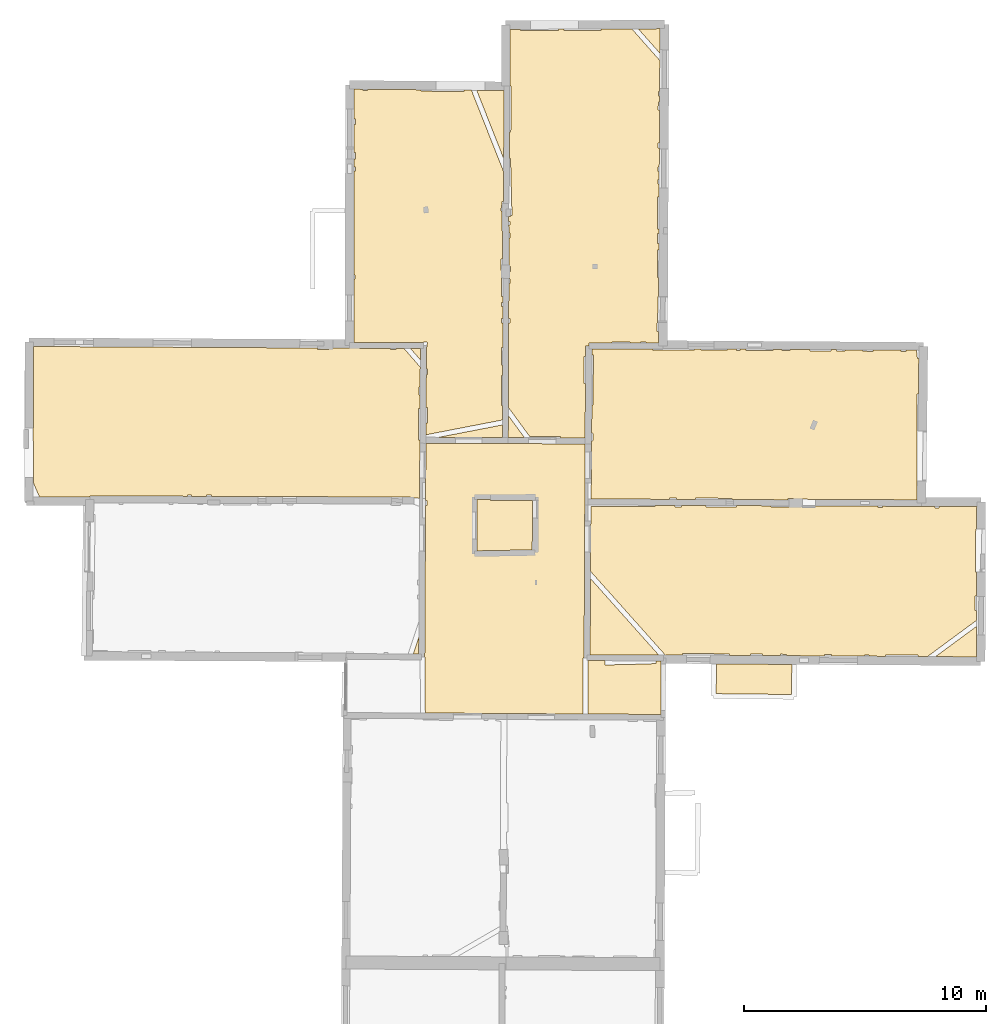
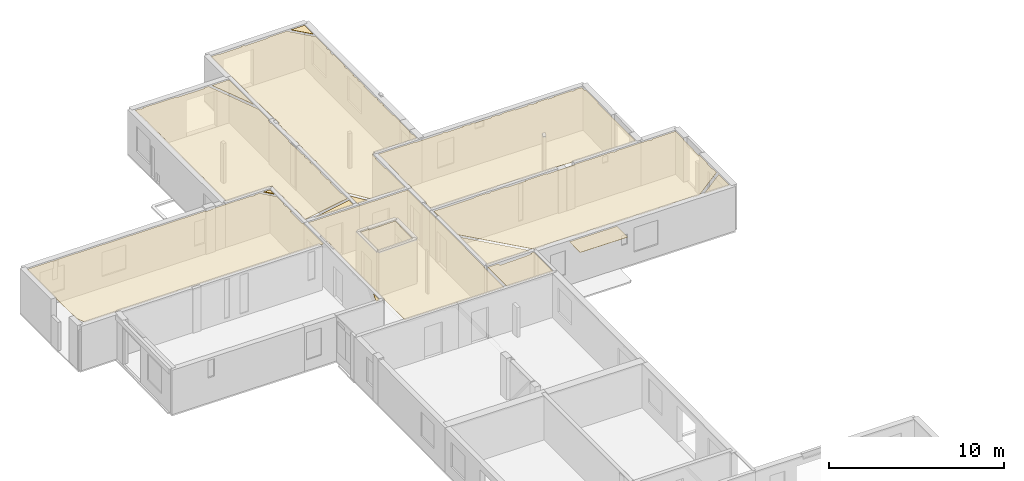
# One storey, part 15 of 17: 17 coverings.
"""IFC2X3 building model written with IfcOpenShell, lengths in metres."""

from ifc_helpers import new_model, entity, si_unit, converted_unit, derived_unit, direction, frame, origin, origin_with_axes, place, context, subcontext, project, spatial, polyline, outline, extrude, material, layer, layer_set, layer_usage, type_object, element, save


model = new_model("IFC2X3")

# Units and contexts
model_context = context("Model", 3, precision=1e-05, world=origin(), true_north=direction((0.0, 1.0)))
body_context = subcontext(model_context, "Body", "Model", "MODEL_VIEW")
ifc_project = project(units=[si_unit("LENGTHUNIT", "METRE"), si_unit("AREAUNIT", "SQUARE_METRE"), si_unit("VOLUMEUNIT", "CUBIC_METRE"), converted_unit("PLANEANGLEUNIT", "DEGREE", entity("IfcRatioMeasure", 0.0174532925199433), si_unit("PLANEANGLEUNIT", "RADIAN"), dimensions=[0, 0, 0, 0, 0, 0, 0]), si_unit("MASSUNIT", "GRAM", prefix="KILO"), derived_unit("MASSDENSITYUNIT", [(si_unit("MASSUNIT", "GRAM", prefix="KILO"), 1), (si_unit("LENGTHUNIT", "METRE"), -3)]), derived_unit("MOMENTOFINERTIAUNIT", [(si_unit("LENGTHUNIT", "METRE"), 4)]), si_unit("TIMEUNIT", "SECOND"), si_unit("FREQUENCYUNIT", "HERTZ"), si_unit("THERMODYNAMICTEMPERATUREUNIT", "DEGREE_CELSIUS"), derived_unit("THERMALTRANSMITTANCEUNIT", [(si_unit("MASSUNIT", "GRAM", prefix="KILO"), 1), (si_unit("THERMODYNAMICTEMPERATUREUNIT", "KELVIN"), -1), (si_unit("TIMEUNIT", "SECOND"), -3)]), derived_unit("VOLUMETRICFLOWRATEUNIT", [(si_unit("LENGTHUNIT", "METRE"), 3), (si_unit("TIMEUNIT", "SECOND"), -1)]), si_unit("ELECTRICCURRENTUNIT", "AMPERE"), si_unit("ELECTRICVOLTAGEUNIT", "VOLT"), si_unit("POWERUNIT", "WATT"), si_unit("FORCEUNIT", "NEWTON", prefix="KILO"), si_unit("ILLUMINANCEUNIT", "LUX"), si_unit("LUMINOUSFLUXUNIT", "LUMEN"), si_unit("LUMINOUSINTENSITYUNIT", "CANDELA"), derived_unit("USERDEFINED", [(si_unit("MASSUNIT", "GRAM", prefix="KILO"), -1), (si_unit("LENGTHUNIT", "METRE"), -2), (si_unit("TIMEUNIT", "SECOND"), 3), (si_unit("LUMINOUSFLUXUNIT", "LUMEN"), 1)]), derived_unit("LINEARVELOCITYUNIT", [(si_unit("LENGTHUNIT", "METRE"), 1), (si_unit("TIMEUNIT", "SECOND"), -1)]), si_unit("PRESSUREUNIT", "PASCAL"), derived_unit("USERDEFINED", [(si_unit("LENGTHUNIT", "METRE"), -2), (si_unit("MASSUNIT", "GRAM", prefix="KILO"), 1), (si_unit("TIMEUNIT", "SECOND"), -2)]), derived_unit("LINEARFORCEUNIT", [(si_unit("MASSUNIT", "GRAM", prefix="KILO"), 1), (si_unit("LENGTHUNIT", "METRE"), 1), (si_unit("TIMEUNIT", "SECOND"), -2), (si_unit("LENGTHUNIT", "METRE"), -1)]), derived_unit("PLANARFORCEUNIT", [(si_unit("MASSUNIT", "GRAM", prefix="KILO"), 1), (si_unit("LENGTHUNIT", "METRE"), 1), (si_unit("TIMEUNIT", "SECOND"), -2), (si_unit("LENGTHUNIT", "METRE"), -2)])], contexts=[model_context])

# Site, building, storey
placement = place(None, origin())
site = spatial("IfcSite", under=ifc_project, at=placement, CompositionType="ELEMENT")
building = spatial("IfcBuilding", under=site, at=placement, CompositionType="ELEMENT")
storey_placement = place(placement, frame((0.0, 0.0, 12.0782108306885)))
storey = spatial("IfcBuildingStorey", under=building, at=storey_placement, Name="Level 5", CompositionType="ELEMENT", Elevation=12.0782108306885)

# Coverings
ifc_material = material(Name="Covering default")
ifc_layer_1 = layer(ifc_material, 0.02)
ifc_layer_set_1 = layer_set([ifc_layer_1], Name="Covering : 20mm")
ifc_layer_usage_1 = layer_usage(ifc_layer_set_1, "AXIS3", "POSITIVE", 0.0)
covering_type_1 = type_object("IfcCoveringType", Name="Covering : 20mm", PredefinedType="CEILING")
covering_1_placement = place(placement, frame((0.0, 0.0, 15.0685014724731)))
element("IfcCovering", 1, at=covering_1_placement, inside=storey, type_object=covering_type_1, material=ifc_layer_usage_1, Name="Covering : 20mm", ObjectType="Covering : 20mm", PredefinedType="CEILING", context=body_context, shape_type="SweptSolid", body=[
    extrude(outline(polyline([(9.7904806137085, 51.0600814819336), (10.4933347702026, 51.0579490661621), (10.4976015090942, 50.8820762634277), (12.4128408432007, 50.9285469055176), (12.4123678207397, 50.9480133056641), (12.6124906539917, 50.9501876831055), (12.6113901138306, 51.0515213012695), (12.8225831985474, 51.0508804321289), (12.8118028640747, 48.838264465332), (9.79118824005127, 48.856689453125), (9.7904806137085, 51.0600814819336)])), origin_with_axes(), (0.0, 0.0, 1.0), 0.02),
])
ifc_layer_2 = layer(ifc_material, 0.02)
ifc_layer_set_2 = layer_set([ifc_layer_2], Name="Covering : 20mm")
ifc_layer_usage_2 = layer_usage(ifc_layer_set_2, "AXIS3", "POSITIVE", 0.0)
covering_type_2 = type_object("IfcCoveringType", Name="Covering : 20mm", PredefinedType="CEILING")
covering_2_placement = place(placement, frame((0.0, 0.0, 15.0685014724731)))
element("IfcCovering", 2, at=covering_2_placement, inside=storey, type_object=covering_type_2, material=ifc_layer_usage_2, Name="Covering : 20mm", ObjectType="Covering : 20mm", PredefinedType="CEILING", context=body_context, shape_type="SweptSolid", body=[
    extrude(outline(polyline([(3.08351039886475, 57.4632720947266), (3.13843250274658, 57.4632911682129), (3.13836765289307, 57.6694068908691), (3.08463573455811, 57.6693878173828), (3.09758472442627, 60.0438919067383), (9.67573261260986, 60.0161056518555), (9.66755962371826, 58.3527603149414), (9.63231945037842, 51.1803703308105), (9.59044361114502, 51.1803550720215), (9.59118938446045, 48.85791015625), (6.44472026824951, 48.8771018981934), (6.44472026824951, 48.8771018981934), (3.07143878936768, 48.8976783752441), (3.05984020233154, 51.210807800293), (3.04940891265869, 51.2107543945312), (3.08351039886475, 57.4632720947266)])), origin_with_axes(), (0.0, 0.0, 1.0), 0.02),
])
ifc_layer_3 = layer(ifc_material, 0.02)
ifc_layer_set_3 = layer_set([ifc_layer_3], Name="Covering : 20mm")
ifc_layer_usage_3 = layer_usage(ifc_layer_set_3, "AXIS3", "POSITIVE", 0.0)
covering_type_3 = type_object("IfcCoveringType", Name="Covering : 20mm", PredefinedType="CEILING")
covering_3_placement = place(placement, frame((0.0, 0.0, 15.0685014724731)))
element("IfcCovering", 3, at=covering_3_placement, inside=storey, type_object=covering_type_3, material=ifc_layer_usage_3, Name="Covering : 20mm", ObjectType="Covering : 20mm", PredefinedType="CEILING", context=body_context, shape_type="SweptSolid", body=[
    extrude(outline(polyline([(15.1055517196655, 50.9264907836914), (18.2173767089844, 50.906078338623), (18.2084465026855, 49.662410736084), (15.090048789978, 49.6961326599121), (15.1055517196655, 50.9264907836914)])), origin_with_axes(), (0.0, 0.0, 1.0), 0.02),
])
ifc_layer_4 = layer(ifc_material, 0.02)
ifc_layer_set_4 = layer_set([ifc_layer_4], Name="Covering : 20mm")
ifc_layer_usage_4 = layer_usage(ifc_layer_set_4, "AXIS3", "POSITIVE", 0.0)
covering_type_4 = type_object("IfcCoveringType", Name="Covering : 20mm", PredefinedType="CEILING")
covering_4_placement = place(placement, frame((0.0, 0.0, 15.0685014724731)))
element("IfcCovering", 4, at=covering_4_placement, inside=storey, type_object=covering_type_4, material=ifc_layer_usage_4, Name="Covering : 20mm", ObjectType="Covering : 20mm", PredefinedType="CEILING", context=body_context, shape_type="SweptSolid", body=[
    extrude(outline(polyline([(24.1548767089844, 51.2271385192871), (25.8434677124023, 52.4721984863281), (25.8394622802734, 51.2160873413086), (24.1548767089844, 51.2271385192871)])), origin_with_axes(), (0.0, 0.0, 1.0), 0.02),
])
ifc_layer_5 = layer(ifc_material, 0.02)
ifc_layer_set_5 = layer_set([ifc_layer_5], Name="Covering : 20mm")
ifc_layer_usage_5 = layer_usage(ifc_layer_set_5, "AXIS3", "POSITIVE", 0.0)
covering_type_5 = type_object("IfcCoveringType", Name="Covering : 20mm", PredefinedType="CEILING")
covering_5_placement = place(placement, frame((0.0, 0.0, 15.0685014724731)))
element("IfcCovering", 5, at=covering_5_placement, inside=storey, type_object=covering_type_5, material=ifc_layer_usage_5, Name="Covering : 20mm", ObjectType="Covering : 20mm", PredefinedType="CEILING", context=body_context, shape_type="SweptSolid", body=[
    extrude(outline(polyline([(13.0087194442749, 51.2693481445312), (13.00892162323, 51.3002510070801), (13.7004079818726, 51.2957153320312), (13.7003927230835, 51.3473663330078), (15.0095586776733, 51.3477821350098), (15.0095624923706, 51.3377838134766), (15.6403951644897, 51.3379859924316), (15.6404123306274, 51.2829895019531), (16.500415802002, 51.2773475646973), (16.5004005432129, 51.3282623291016), (17.0103988647461, 51.3284225463867), (17.0104141235352, 51.2740020751953), (17.7579345703125, 51.269100189209), (17.7603988647461, 51.3286628723145), (18.0004005432129, 51.3187408447266), (17.9982833862305, 51.2675247192383), (19.5704193115234, 51.257209777832), (19.5704040527344, 51.3092422485352), (19.8504066467285, 51.3093338012695), (19.8504257202148, 51.2553749084473), (21.2304267883301, 51.2463226318359), (21.2304077148438, 51.2997741699219), (21.4104080200195, 51.2998352050781), (21.4104270935059, 51.2451400756836), (22.0899848937988, 51.2406845092773), (22.0904083251953, 51.300048828125), (23.4304122924805, 51.2904815673828), (23.4299926757812, 51.2318916320801), (23.8208427429199, 51.2293281555176), (25.8442649841309, 52.7212715148926), (25.8456039428711, 53.1412544250488), (25.7898216247559, 53.1412353515625), (25.7896270751953, 53.7412338256836), (25.8475151062012, 53.7412528991699), (25.8506393432617, 54.7206802368164), (25.7993125915527, 54.7212371826172), (25.8187408447266, 56.5112457275391), (25.8563461303711, 56.5108375549316), (25.8592872619629, 57.4330902099609), (24.3084487915039, 57.4254455566406), (24.3084678649902, 57.3707618713379), (24.1384658813477, 57.3707046508789), (24.1384468078613, 57.4246063232422), (23.578426361084, 57.4218444824219), (23.5783615112305, 57.4350357055664), (21.9684410095215, 57.4415512084961), (21.9684600830078, 57.3900146484375), (21.7684593200684, 57.3899459838867), (21.768440246582, 57.4423599243164), (19.1881828308105, 57.4528007507324), (19.1884460449219, 57.4291229248047), (17.3484535217285, 57.4085311889648), (17.3478736877441, 57.4602394104004), (15.9288911819458, 57.4659805297852), (15.9284505844116, 57.4080772399902), (14.6684484481812, 57.4176750183105), (14.6688547134399, 57.471076965332), (13.6584310531616, 57.4751663208008), (13.6584501266479, 57.417350769043), (13.3884496688843, 57.4172668457031), (13.3884305953979, 57.4762573242188), (12.5686368942261, 57.4795761108398), (12.5684461593628, 57.427001953125), (9.91423511505127, 57.4366035461426), (9.91261959075928, 57.3470039367676), (9.89987468719482, 54.7527770996094), (13.0087194442749, 51.2693481445312)])), origin_with_axes(), (0.0, 0.0, 1.0), 0.02),
])
ifc_layer_6 = layer(ifc_material, 0.02)
ifc_layer_set_6 = layer_set([ifc_layer_6], Name="Covering : 20mm")
ifc_layer_usage_6 = layer_usage(ifc_layer_set_6, "AXIS3", "POSITIVE", 0.0)
covering_type_6 = type_object("IfcCoveringType", Name="Covering : 20mm", PredefinedType="CEILING")
covering_6_placement = place(placement, frame((0.0, 0.0, 15.0685014724731)))
element("IfcCovering", 6, at=covering_6_placement, inside=storey, type_object=covering_type_6, material=ifc_layer_usage_6, Name="Covering : 20mm", ObjectType="Covering : 20mm", PredefinedType="CEILING", context=body_context, shape_type="SweptSolid", body=[
    extrude(outline(polyline([(9.89840793609619, 54.4540519714355), (12.7201337814331, 51.2923355102539), (9.88291072845459, 51.2998008728027), (9.89840793609619, 54.4540519714355)])), origin_with_axes(), (0.0, 0.0, 1.0), 0.02),
])
ifc_layer_7 = layer(ifc_material, 0.02)
ifc_layer_set_7 = layer_set([ifc_layer_7], Name="Covering : 20mm")
ifc_layer_usage_7 = layer_usage(ifc_layer_set_7, "AXIS3", "POSITIVE", 0.0)
covering_type_7 = type_object("IfcCoveringType", Name="Covering : 20mm", PredefinedType="CEILING")
covering_7_placement = place(placement, frame((0.0, 0.0, 15.0685014724731)))
element("IfcCovering", 7, at=covering_7_placement, inside=storey, type_object=covering_type_7, material=ifc_layer_usage_7, Name="Covering : 20mm", ObjectType="Covering : 20mm", PredefinedType="CEILING", context=body_context, shape_type="SweptSolid", body=[
    extrude(outline(polyline([(2.80388736724854, 52.0325698852539), (2.80006504058838, 51.331672668457), (2.57115459442139, 51.3336219787598), (2.80388736724854, 52.0325698852539)])), origin_with_axes(), (0.0, 0.0, 1.0), 0.02),
])
ifc_layer_8 = layer(ifc_material, 0.02)
ifc_layer_set_8 = layer_set([ifc_layer_8], Name="Covering : 20mm")
ifc_layer_usage_8 = layer_usage(ifc_layer_set_8, "AXIS3", "POSITIVE", 0.0)
covering_type_8 = type_object("IfcCoveringType", Name="Covering : 20mm", PredefinedType="CEILING")
covering_8_placement = place(placement, frame((0.0, 0.0, 15.0685014724731)))
element("IfcCovering", 8, at=covering_8_placement, inside=storey, type_object=covering_type_8, material=ifc_layer_usage_8, Name="Covering : 20mm", ObjectType="Covering : 20mm", PredefinedType="CEILING", context=body_context, shape_type="SweptSolid", body=[
    extrude(outline(polyline([(5.20810413360596, 57.7236480712891), (5.77539920806885, 57.7263565063477), (5.77566814422607, 57.6787643432617), (7.50057125091553, 57.6885032653809), (7.49057674407959, 55.6396179199219), (5.20288181304932, 55.5982627868652), (5.20810413360596, 57.7236480712891)])), origin_with_axes(), (0.0, 0.0, 1.0), 0.02),
])
ifc_layer_9 = layer(ifc_material, 0.02)
ifc_layer_set_9 = layer_set([ifc_layer_9], Name="Covering : 20mm")
ifc_layer_usage_9 = layer_usage(ifc_layer_set_9, "AXIS3", "POSITIVE", 0.0)
covering_type_9 = type_object("IfcCoveringType", Name="Covering : 20mm", PredefinedType="CEILING")
covering_9_placement = place(placement, frame((0.0, 0.0, 15.0685014724731)))
element("IfcCovering", 9, at=covering_9_placement, inside=storey, type_object=covering_type_9, material=ifc_layer_usage_9, Name="Covering : 20mm", ObjectType="Covering : 20mm", PredefinedType="CEILING", context=body_context, shape_type="SweptSolid", body=[
    extrude(outline(polyline([(9.93150424957275, 58.3950958251953), (9.93776988983154, 58.3950653076172), (9.94572925567627, 60.0148696899414), (9.94572925567627, 60.0148696899414), (9.94633007049561, 60.1373023986816), (9.99067211151123, 60.1349830627441), (10.0074758529663, 60.456184387207), (9.94791316986084, 60.459300994873), (9.95364856719971, 61.6264228820801), (10.0071020126343, 61.6261825561523), (10.0164384841919, 63.6961860656738), (9.96381855010986, 63.6964225769043), (9.96505069732666, 63.9469871520996), (12.476056098938, 63.9395027160645), (12.4763765335083, 63.8869743347168), (14.206374168396, 63.897533416748), (14.2060689926147, 63.947566986084), (14.4663572311401, 63.9458656311035), (14.4663763046265, 63.8876152038574), (15.5563764572144, 63.8879661560059), (15.5563592910767, 63.9387245178223), (15.9263601303101, 63.9362983703613), (15.9263792037964, 63.8780784606934), (16.0863800048828, 63.8781318664551), (16.0863609313965, 63.9352531433105), (16.3268623352051, 63.9336738586426), (16.3263816833496, 63.8782081604004), (17.4363822937012, 63.8685646057129), (17.4368858337402, 63.9264030456543), (17.8163642883301, 63.9239158630371), (17.8163833618164, 63.8686866760254), (18.1463851928711, 63.8687934875488), (18.1463661193848, 63.9217567443848), (18.9663696289062, 63.9163856506348), (18.9663887023926, 63.8590507507324), (19.8363876342773, 63.8593330383301), (19.8363723754883, 63.9106864929199), (20.0563735961914, 63.9092445373535), (20.0563926696777, 63.8493995666504), (20.416389465332, 63.8495216369629), (20.4163703918457, 63.9068870544434), (21.147590637207, 63.9020957946777), (21.1463890075684, 63.8497505187988), (21.5763931274414, 63.8398933410645), (21.5777549743652, 63.8992729187012), (22.7363777160645, 63.8916893005371), (22.7363929748535, 63.840259552002), (22.9263954162598, 63.8403205871582), (22.9263801574707, 63.890438079834), (23.3702659606934, 63.8875312805176), (23.4064865112305, 63.550479888916), (23.4652824401855, 63.5567970275879), (23.4472236633301, 62.0803451538086), (23.3969573974609, 62.0804672241211), (23.3937110900879, 57.7057838439941), (19.1945037841797, 57.7227745056152), (19.1944885253906, 57.7189064025879), (18.0683403015137, 57.7587623596191), (18.0665168762207, 57.707332611084), (15.7480154037476, 57.7167129516602), (15.7483358383179, 57.7680206298828), (14.2283315658569, 57.7775344848633), (14.2279901504517, 57.7228622436523), (13.4483480453491, 57.726016998291), (13.4483327865601, 57.7772827148438), (13.1683340072632, 57.7771949768066), (13.1683492660522, 57.7271499633789), (9.91970539093018, 57.740291595459), (9.93150424957275, 58.3950958251953)])), origin_with_axes(), (0.0, 0.0, 1.0), 0.02),
])
ifc_layer_10 = layer(ifc_material, 0.02)
ifc_layer_set_10 = layer_set([ifc_layer_10], Name="Covering : 20mm")
ifc_layer_usage_10 = layer_usage(ifc_layer_set_10, "AXIS3", "POSITIVE", 0.0)
covering_type_10 = type_object("IfcCoveringType", Name="Covering : 20mm", PredefinedType="CEILING")
covering_10_placement = place(placement, frame((0.0, 0.0, 15.0685014724731)))
element("IfcCovering", 10, at=covering_10_placement, inside=storey, type_object=covering_type_10, material=ifc_layer_usage_10, Name="Covering : 20mm", ObjectType="Covering : 20mm", PredefinedType="CEILING", context=body_context, shape_type="SweptSolid", body=[
    extrude(outline(polyline([(-13.1075763702393, 58.3783416748047), (-12.868932723999, 57.826171875), (-10.7861461639404, 57.8319511413574), (-10.7860221862793, 57.8676414489746), (-6.75169277191162, 57.8536834716797), (-6.75171232223511, 57.910816192627), (-6.58171033859253, 57.9108734130859), (-6.58169078826904, 57.8530960083008), (-5.96169281005859, 57.8509483337402), (-5.96170854568481, 57.9010696411133), (-5.76170778274536, 57.9011344909668), (-5.76169109344482, 57.8502578735352), (2.46896457672119, 57.8217811584473), (2.47573947906494, 57.7743721008301), (2.83518695831299, 57.7711868286133), (2.84826755523682, 60.1697235107422), (2.79756641387939, 60.1697082519531), (2.79714488983154, 61.4838714599609), (2.85543537139893, 61.4838905334473), (2.85848903656006, 62.0438919067383), (2.80696582794189, 62.0438766479492), (2.80686092376709, 62.3738784790039), (2.86028957366943, 62.3738975524902), (2.86472225189209, 63.186595916748), (2.19258403778076, 63.9643592834473), (1.85634994506836, 63.9647331237793), (1.85636711120605, 63.9135780334473), (1.62636756896973, 63.913501739502), (1.62635040283203, 63.9649925231934), (1.13216686248779, 63.9655342102051), (-0.913651466369629, 63.9765205383301), (-0.913634300231934, 63.9226875305176), (-1.38363552093506, 63.9225425720215), (-1.38365364074707, 63.9790458679199), (-13.1240291595459, 64.0420837402344), (-13.1264801025391, 60.6716423034668), (-13.1325941085815, 60.6716461181641), (-13.1324920654297, 60.3525085449219), (-13.1289682388306, 60.3525009155273), (-13.1075763702393, 58.3783416748047)])), origin_with_axes(), (0.0, 0.0, 1.0), 0.02),
])
ifc_layer_11 = layer(ifc_material, 0.02)
ifc_layer_set_11 = layer_set([ifc_layer_11], Name="Covering : 20mm")
ifc_layer_usage_11 = layer_usage(ifc_layer_set_11, "AXIS3", "POSITIVE", 0.0)
covering_type_11 = type_object("IfcCoveringType", Name="Covering : 20mm", PredefinedType="CEILING")
covering_11_placement = place(placement, frame((0.0, 0.0, 15.0685014724731)))
element("IfcCovering", 11, at=covering_11_placement, inside=storey, type_object=covering_type_11, material=ifc_layer_usage_11, Name="Covering : 20mm", ObjectType="Covering : 20mm", PredefinedType="CEILING", context=body_context, shape_type="SweptSolid", body=[
    extrude(outline(polyline([(7.38483905792236, 60.3253440856934), (8.6575174331665, 60.3257522583008), (8.6575345993042, 60.2704048156738), (9.67696094512939, 60.2660980224609), (9.68801593780518, 62.5160789489746), (9.63681697845459, 62.5160636901855), (9.63646221160889, 63.6260643005371), (9.69346904754639, 63.6260795593262), (9.69564151763916, 64.0680541992188), (9.830641746521, 64.0673904418945), (9.83100032806396, 64.187385559082), (10.7962808609009, 64.1845092773438), (10.7962636947632, 64.2364349365234), (11.5262632369995, 64.2366714477539), (11.5262804031372, 64.1823272705078), (11.956280708313, 64.1810455322266), (11.9562635421753, 64.2368087768555), (12.1862630844116, 64.2368774414062), (12.1862802505493, 64.1803588867188), (12.7114896774292, 64.1787948608398), (12.7140283584595, 64.6670455932617), (12.6561269760132, 64.6670303344727), (12.6560182571411, 65.0070343017578), (12.6759080886841, 65.0284881591797), (12.6815595626831, 66.1145858764648), (12.71155834198, 66.1144332885742), (12.7156286239624, 66.8970489501953), (12.6654119491577, 66.8970336914062), (12.6650533676147, 68.0270385742188), (12.7215070724487, 68.0270538330078), (12.7229566574097, 68.3056030273438), (12.6649618148804, 68.3070373535156), (12.6748342514038, 68.7070388793945), (12.7250375747681, 68.7058029174805), (12.7260847091675, 68.9070587158203), (12.6747694015503, 68.9070434570312), (12.6743497848511, 70.217041015625), (12.7328977584839, 70.2170562744141), (12.7356557846069, 70.7470550537109), (12.6841802597046, 70.7470397949219), (12.6841154098511, 70.9470367431641), (12.7366952896118, 70.9470520019531), (12.7384119033813, 71.2770538330078), (12.6840124130249, 71.2770385742188), (12.6839513778687, 71.467041015625), (12.7393999099731, 71.4670562744141), (12.743390083313, 72.2342224121094), (12.6837034225464, 72.2370452880859), (12.6936368942261, 72.4470443725586), (12.7444849014282, 72.4446411132812), (12.7515630722046, 73.8052978515625), (12.6932020187378, 73.8070449829102), (12.7030973434448, 74.1370468139648), (12.7532796859741, 74.1355438232422), (12.7546415328979, 74.3970642089844), (12.703013420105, 74.3970489501953), (12.7029523849487, 74.5870513916016), (12.7556295394897, 74.5870666503906), (12.7622537612915, 75.8607940673828), (11.607798576355, 77.166877746582), (10.3417711257935, 77.161003112793), (10.3421468734741, 77.1062927246094), (8.81214809417725, 77.0958023071289), (8.81174945831299, 77.1539077758789), (8.57213115692139, 77.1527938842773), (8.57215023040771, 77.0957260131836), (7.01214694976807, 77.0952301025391), (7.012131690979, 77.1455535888672), (6.56471729278564, 77.1434783935547), (6.57350254058838, 74.7982711791992), (6.61394786834717, 74.796012878418), (6.60348606109619, 72.9150924682617), (6.54572200775146, 72.915412902832), (6.54383182525635, 71.8150787353516), (6.59383678436279, 71.8150939941406), (6.65459156036377, 69.4651107788086), (6.5994291305542, 69.4627914428711), (6.59828472137451, 69.4083633422852), (6.51803874969482, 69.4100494384766), (6.51960468292236, 69.2050704956055), (6.57467555999756, 69.2050857543945), (6.57472324371338, 69.0550842285156), (6.52074909210205, 69.0550689697266), (6.52319049835205, 68.7350692749023), (6.57482433319092, 68.7350845336914), (6.57489681243896, 68.5150833129883), (6.52487087249756, 68.5150680541992), (6.53374195098877, 67.3526153564453), (6.58526515960693, 67.3550872802734), (6.59533214569092, 67.1450881958008), (6.5353479385376, 67.1422119140625), (6.53769207000732, 66.835075378418), (6.57543468475342, 66.8350830078125), (6.57549381256104, 66.6450805664062), (6.52396869659424, 66.6450653076172), (6.51837635040283, 65.195068359375), (6.57595920562744, 65.1950836181641), (6.57601833343506, 65.0050811767578), (6.51764392852783, 65.0050659179688), (6.50423336029053, 61.5273132324219), (7.38483905792236, 60.3253440856934)])), origin_with_axes(), (0.0, 0.0, 1.0), 0.02),
])
ifc_layer_12 = layer(ifc_material, 0.02)
ifc_layer_set_12 = layer_set([ifc_layer_12], Name="Covering : 20mm")
ifc_layer_usage_12 = layer_usage(ifc_layer_set_12, "AXIS3", "POSITIVE", 0.0)
covering_type_12 = type_object("IfcCoveringType", Name="Covering : 20mm", PredefinedType="CEILING")
covering_12_placement = place(placement, frame((0.0, 0.0, 15.0685014724731)))
element("IfcCovering", 12, at=covering_12_placement, inside=storey, type_object=covering_type_12, material=ifc_layer_usage_12, Name="Covering : 20mm", ObjectType="Covering : 20mm", PredefinedType="CEILING", context=body_context, shape_type="SweptSolid", body=[
    extrude(outline(polyline([(6.50293445587158, 61.1906776428223), (7.17256259918213, 60.2766799926758), (6.49942111968994, 60.2795219421387), (6.50293445587158, 61.1906776428223)])), origin_with_axes(), (0.0, 0.0, 1.0), 0.02),
])
ifc_layer_13 = layer(ifc_material, 0.02)
ifc_layer_set_13 = layer_set([ifc_layer_13], Name="Covering : 20mm")
ifc_layer_usage_13 = layer_usage(ifc_layer_set_13, "AXIS3", "POSITIVE", 0.0)
covering_type_13 = type_object("IfcCoveringType", Name="Covering : 20mm", PredefinedType="CEILING")
covering_13_placement = place(placement, frame((0.0, 0.0, 15.0685014724731)))
element("IfcCovering", 13, at=covering_13_placement, inside=storey, type_object=covering_type_13, material=ifc_layer_usage_13, Name="Covering : 20mm", ObjectType="Covering : 20mm", PredefinedType="CEILING", context=body_context, shape_type="SweptSolid", body=[
    extrude(outline(polyline([(3.62903881072998, 60.2916488647461), (6.26143169403076, 60.8017349243164), (6.25942134857178, 60.2805366516113), (3.62903881072998, 60.2916488647461)])), origin_with_axes(), (0.0, 0.0, 1.0), 0.02),
])
ifc_layer_14 = layer(ifc_material, 0.02)
ifc_layer_set_14 = layer_set([ifc_layer_14], Name="Covering : 20mm")
ifc_layer_usage_14 = layer_usage(ifc_layer_set_14, "AXIS3", "POSITIVE", 0.0)
covering_type_14 = type_object("IfcCoveringType", Name="Covering : 20mm", PredefinedType="CEILING")
covering_14_placement = place(placement, frame((0.0, 0.0, 15.0685014724731)))
element("IfcCovering", 14, at=covering_14_placement, inside=storey, type_object=covering_type_14, material=ifc_layer_usage_14, Name="Covering : 20mm", ObjectType="Covering : 20mm", PredefinedType="CEILING", context=body_context, shape_type="SweptSolid", body=[
    extrude(outline(polyline([(0.120447158813477, 66.8330230712891), (0.175432205200195, 66.8330383300781), (0.175380706787109, 66.993034362793), (0.120625495910645, 66.9930191040039), (0.125410079956055, 71.2930297851562), (0.184004783630371, 71.2930450439453), (0.183953285217285, 71.4530410766602), (0.125588417053223, 71.4530258178711), (0.125967025756836, 71.7930297851562), (0.183844566345215, 71.7930450439453), (0.183757781982422, 72.0630416870117), (0.126267433166504, 72.0630264282227), (0.127557754516602, 73.2230224609375), (0.18338680267334, 73.2230377197266), (0.183316230773926, 73.4430389404297), (0.127802848815918, 73.4430236816406), (0.129172325134277, 74.6739883422852), (0.502921104431152, 74.6706314086914), (0.502941131591797, 74.6131439208984), (0.682941436767578, 74.6132049560547), (0.68292236328125, 74.6690063476562), (2.90355396270752, 74.649040222168), (2.90294933319092, 74.5939102172852), (4.67295360565186, 74.5744781494141), (4.67359828948975, 74.6331176757812), (4.98094272613525, 74.6303558349609), (6.31287288665771, 71.255744934082), (6.31077861785889, 70.0365447998047), (6.25440502166748, 70.0449829101562), (6.1945333480835, 69.6449584960938), (6.24629688262939, 69.6372146606445), (6.26142024993896, 67.6557159423828), (6.20517063140869, 67.6549682617188), (6.22566699981689, 66.1049728393555), (6.28188610076904, 66.1057205200195), (6.2809591293335, 65.864990234375), (6.22574329376221, 65.8649749755859), (6.22580242156982, 65.6849746704102), (6.28026485443115, 65.6849899291992), (6.27837467193604, 65.1949920654297), (6.22595882415771, 65.1949768066406), (6.22601985931396, 65.0049743652344), (6.27764225006104, 65.0049896240234), (6.27378559112549, 64.0049819946289), (6.21633815765381, 64.0049667358398), (6.21657276153564, 63.2749710083008), (6.27097034454346, 63.2749900817871), (6.26931095123291, 62.8449859619141), (6.21671009063721, 62.844970703125), (6.2171049118042, 61.6134948730469), (6.26456165313721, 61.6135101318359), (6.26221752166748, 61.0056037902832), (3.09948825836182, 60.3927536010742), (3.10211277008057, 60.8739738464355), (3.15734195709229, 60.8739929199219), (3.15713405609131, 61.5239906311035), (3.10565853118896, 61.5239753723145), (3.11307621002197, 62.883975982666), (3.16669750213623, 62.8839950561523), (3.16662693023682, 63.1059265136719), (3.11428546905518, 63.1059112548828), (3.11926746368408, 64.0191345214844), (3.13235187530518, 64.0168838500977), (3.16627216339111, 64.2139892578125), (3.01189708709717, 64.2405548095703), (2.99470043182373, 64.1406326293945), (2.99478244781494, 64.2134704589844), (0.117535591125488, 64.2166595458984), (0.120447158813477, 66.8330230712891)])), origin_with_axes(), (0.0, 0.0, 1.0), 0.02),
])
ifc_layer_15 = layer(ifc_material, 0.02)
ifc_layer_set_15 = layer_set([ifc_layer_15], Name="Covering : 20mm")
ifc_layer_usage_15 = layer_usage(ifc_layer_set_15, "AXIS3", "POSITIVE", 0.0)
covering_type_15 = type_object("IfcCoveringType", Name="Covering : 20mm", PredefinedType="CEILING")
covering_15_placement = place(placement, frame((0.0, 0.0, 15.0685014724731)))
element("IfcCovering", 15, at=covering_15_placement, inside=storey, type_object=covering_type_15, material=ifc_layer_usage_15, Name="Covering : 20mm", ObjectType="Covering : 20mm", PredefinedType="CEILING", context=body_context, shape_type="SweptSolid", body=[
    extrude(outline(polyline([(2.866379737854, 63.4905548095703), (2.8689603805542, 63.9636116027832), (2.45717525482178, 63.9640693664551), (2.866379737854, 63.4905548095703)])), origin_with_axes(), (0.0, 0.0, 1.0), 0.02),
])
ifc_layer_16 = layer(ifc_material, 0.02)
ifc_layer_set_16 = layer_set([ifc_layer_16], Name="Covering : 20mm")
ifc_layer_usage_16 = layer_usage(ifc_layer_set_16, "AXIS3", "POSITIVE", 0.0)
covering_type_16 = type_object("IfcCoveringType", Name="Covering : 20mm", PredefinedType="CEILING")
covering_16_placement = place(placement, frame((0.0, 0.0, 15.0685014724731)))
element("IfcCovering", 16, at=covering_16_placement, inside=storey, type_object=covering_type_16, material=ifc_layer_usage_16, Name="Covering : 20mm", ObjectType="Covering : 20mm", PredefinedType="CEILING", context=body_context, shape_type="SweptSolid", body=[
    extrude(outline(polyline([(6.31380367279053, 71.7981491088867), (6.31864452362061, 74.6183242797852), (5.19672107696533, 74.62841796875), (6.31380367279053, 71.7981491088867)])), origin_with_axes(), (0.0, 0.0, 1.0), 0.02),
])
ifc_layer_17 = layer(ifc_material, 0.02)
ifc_layer_set_17 = layer_set([ifc_layer_17], Name="Covering : 20mm")
ifc_layer_usage_17 = layer_usage(ifc_layer_set_17, "AXIS3", "POSITIVE", 0.0)
covering_type_17 = type_object("IfcCoveringType", Name="Covering : 20mm", PredefinedType="CEILING")
covering_17_placement = place(placement, frame((0.0, 0.0, 15.0685014724731)))
element("IfcCovering", 17, at=covering_17_placement, inside=storey, type_object=covering_type_17, material=ifc_layer_usage_17, Name="Covering : 20mm", ObjectType="Covering : 20mm", PredefinedType="CEILING", context=body_context, shape_type="SweptSolid", body=[
    extrude(outline(polyline([(12.7638158798218, 76.1610107421875), (12.7690763473511, 77.1722717285156), (11.8736352920532, 77.1681137084961), (12.7638158798218, 76.1610107421875)])), origin_with_axes(), (0.0, 0.0, 1.0), 0.02),
])

save(model, "model.ifc")
